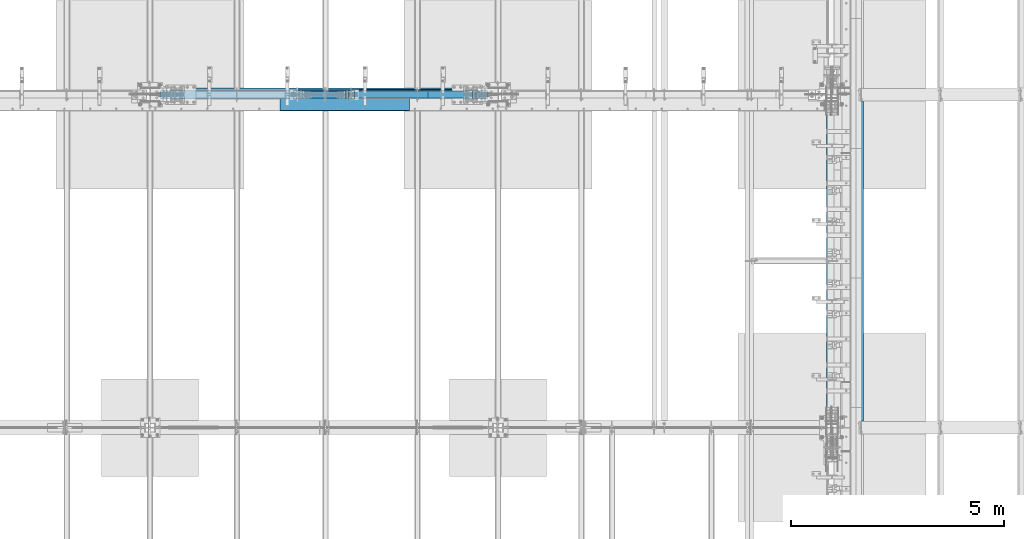
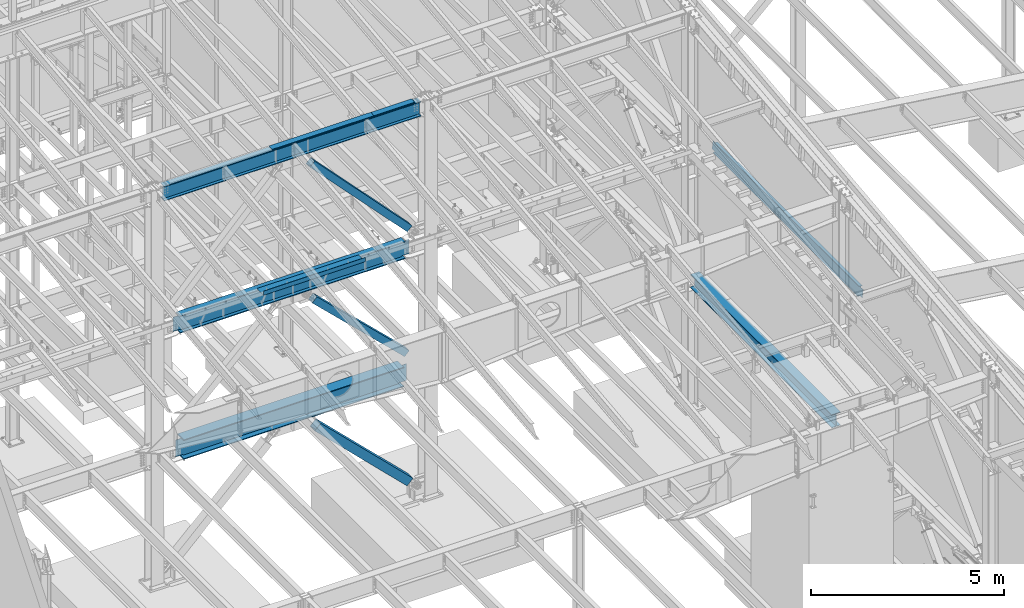
# One storey, part 737 of 1179: 8 beams, 3 members, 8 elements without a shape of their own.
"""IFC2X3 building model written with IfcOpenShell, lengths in millimetres."""

from ifc_helpers import new_model, si_unit, frame, origin_with_axes, place, context, subcontext, project, spatial, faceted_brep, material, type_object, element, aggregate, save


model = new_model("IFC2X3")

# Units and contexts
model_context = context("Model", 3, precision=1e-05, world=origin_with_axes())
body_context = subcontext(model_context, "Body", "Model", "MODEL_VIEW")
ifc_project = project(units=[si_unit("LENGTHUNIT", "METRE", prefix="MILLI"), si_unit("AREAUNIT", "SQUARE_METRE"), si_unit("VOLUMEUNIT", "CUBIC_METRE"), si_unit("MASSUNIT", "GRAM", prefix="KILO"), si_unit("TIMEUNIT", "SECOND"), si_unit("PLANEANGLEUNIT", "RADIAN"), si_unit("SOLIDANGLEUNIT", "STERADIAN"), si_unit("THERMODYNAMICTEMPERATUREUNIT", "DEGREE_CELSIUS"), si_unit("LUMINOUSINTENSITYUNIT", "LUMEN")], contexts=[model_context])

# Site, building, storey
site_placement = place(None, origin_with_axes())
site = spatial("IfcSite", under=ifc_project, at=site_placement, CompositionType="ELEMENT")
building_placement = place(site_placement, origin_with_axes())
building = spatial("IfcBuilding", under=site, at=building_placement, Name="Undefined", CompositionType="ELEMENT")
storey_placement = place(building_placement, origin_with_axes())
storey = spatial("IfcBuildingStorey", under=building, at=storey_placement, Name="Undefined", CompositionType="ELEMENT", Elevation=0.0)

# Assembly, beams
assembly_1_placement = place(storey_placement, origin_with_axes())
assembly_1 = element("IfcElementAssembly", 1, at=assembly_1_placement, inside=storey, Name="BEAM", AssemblyPlace="NOTDEFINED", PredefinedType="RIGID_FRAME")
ifc_material_1 = material(Name="STEEL/A36")
beam_type_1 = type_object("IfcBeamType", PredefinedType="NOTDEFINED")
beam_1_placement = place(assembly_1_placement, frame((15417.8000078236, 27124.0249999997, 12269.3906250174), z_axis=(-1.0, 0.0, 0.0), x_axis=(0.0, 0.0, 1.0)))
beam_1 = element("IfcBeam", 2, at=beam_1_placement, type_object=beam_type_1, material=ifc_material_1, Name="BENT_PLATE", context=body_context, shape_type="Brep", body=[
    faceted_brep([(-2.91038304567337e-11, -4.76250000000073, -609.6), (-2.91038304567337e-11, -4.76250000000073, 609.6), (2.91038304567337e-11, 4.76250000000073, 609.6), (2.91038304567337e-11, 4.76250000000073, -609.6), (43.0065173010735, 4.76249999974607, 609.6), (43.0065173010735, 4.76249999974607, -609.6), (32.3445868583403, -4.7625000001899, -609.6), (32.3445868583403, -4.7625000001899, 609.6), (25.4267481938641, -150.812499999749, 609.6), (25.4267481938641, -150.812499999749, -609.6), (16.9174425397669, -141.287499999748, -609.6), (16.9174425397669, -141.287499999748, 609.6), (3.04971763398498e-08, -150.812499999749, 609.6), (3.04971763398498e-08, -150.812499999749, -609.6), (3.04971763398498e-08, -141.287499999748, 609.6), (3.04971763398498e-08, -141.287499999748, -609.6)], [[[0, 1, 2, 3]], [[3, 2, 4, 5]], [[1, 0, 6, 7]], [[5, 4, 8, 9]], [[7, 6, 10, 11]], [[9, 8, 12, 13]], [[8, 4, 2, 1, 7, 11, 14, 12]], [[11, 10, 15, 14]], [[10, 6, 0, 3, 5, 9, 13, 15]], [[14, 15, 13, 12]]]),
])
beam_2_placement = place(assembly_1_placement, frame((13284.2000078249, 27124.025, 12269.3906249899), z_axis=(-1.0, 0.0, 0.0), x_axis=(0.0, 0.0, 1.0)))
beam_2 = element("IfcBeam", 3, at=beam_2_placement, type_object=beam_type_1, material=ifc_material_1, Name="BENT_PLATE", context=body_context, shape_type="Brep", body=[
    faceted_brep([(-2.91038304567337e-11, -4.76250000000073, -1524.0), (-2.91038304567337e-11, -4.76250000000073, 1524.0), (2.91038304567337e-11, 4.76250000000073, 1524.0), (2.91038304567337e-11, 4.76250000000073, -1524.0), (43.0065173285329, 4.76249999974607, 1524.0), (43.0065173285329, 4.76249999974607, -1524.0), (32.344586885798, -4.7625000001899, -1524.0), (32.344586885798, -4.7625000001899, 1524.0), (25.4267482213236, -150.812499999749, 1524.0), (25.4267482213236, -150.812499999749, -1524.0), (16.9174425672263, -141.287499999748, -1524.0), (16.9174425672263, -141.287499999748, 1524.0), (8.54161044117063e-08, -150.812499999749, 1524.0), (8.54161044117063e-08, -150.812499999749, -1524.0), (8.54161044117063e-08, -141.287499999748, 1524.0), (8.54161044117063e-08, -141.287499999748, -1524.0)], [[[0, 1, 2, 3]], [[3, 2, 4, 5]], [[1, 0, 6, 7]], [[5, 4, 8, 9]], [[7, 6, 10, 11]], [[9, 8, 12, 13]], [[8, 4, 2, 1, 7, 11, 14, 12]], [[11, 10, 15, 14]], [[10, 6, 0, 3, 5, 9, 13, 15]], [[14, 15, 13, 12]]]),
])

# Assembly, member
assembly_2_placement = place(storey_placement, origin_with_axes())
assembly_2 = element("IfcElementAssembly", 4, at=assembly_2_placement, inside=storey, Name="None", AssemblyPlace="NOTDEFINED", PredefinedType="RIGID_FRAME")
ifc_material_2 = material(Name="STEEL/A992")
member_type_1 = type_object("IfcMemberType", Name="HSS8X8X3/16", PredefinedType="NOTDEFINED")
member_1_placement = place(assembly_2_placement, frame((15866.9113752834, 27051.0, 8361.41390796692), z_axis=(0.0, 1.0, 0.0), x_axis=(-0.689394506161204, 0.0, 0.724386095169385)))
member_1 = element("IfcMember", 5, at=member_1_placement, type_object=member_type_1, material=ifc_material_2, Name="None", ObjectType="HSS8X8X3/16", context=body_context, shape_type="Brep", body=[
    faceted_brep([(-3.63797880709171e-12, 96.8374999999978, -96.8375000000015), (-3.63797880709171e-12, -96.8374999999978, -96.8375000000015), (4230.75809404147, -96.8375000024389, -96.8375000000015), (4230.75809404158, 96.8374999976659, -96.8375000000015), (-3.63797880709171e-12, -96.8374999999978, 96.8375000000015), (4230.75809404147, -96.8375000024389, 96.8375000000015), (-3.63797880709171e-12, 96.8374999999978, 96.8375000000015), (4230.75809404158, 96.8374999976659, 96.8375000000015), (-3.63797880709171e-12, 101.599999999999, -101.599999999999), (-3.63797880709171e-12, 101.599999999999, 101.599999999999), (4230.75809404159, 101.59999999767, 101.599999999999), (4230.75809404159, 101.59999999767, -101.599999999999), (0.0, -101.599999999999, 101.599999999999), (4230.75809404147, -101.600000002443, 101.599999999999), (0.0, -101.599999999999, -101.599999999999), (4230.75809404147, -101.600000002443, -101.599999999999)], [[[0, 1, 2, 3]], [[1, 4, 5, 2]], [[4, 6, 7, 5]], [[6, 0, 3, 7]], [[8, 9, 10, 11]], [[9, 12, 13, 10]], [[12, 14, 15, 13]], [[14, 8, 11, 15]], [[13, 15, 11, 10], [5, 7, 3, 2]], [[14, 12, 9, 8], [6, 4, 1, 0]]]),
])
aggregate(assembly_2, [member_1])

assembly_3_placement = place(storey_placement, origin_with_axes())
assembly_3 = element("IfcElementAssembly", 6, at=assembly_3_placement, inside=storey, Name="None", AssemblyPlace="NOTDEFINED", PredefinedType="RIGID_FRAME")
member_2_placement = place(assembly_3_placement, frame((15784.281515407, 27051.0, 4443.21300540147), z_axis=(0.0, 1.0, 0.0), x_axis=(-0.719495300867138, 0.0, 0.694497308871752)))
member_2 = element("IfcMember", 7, at=member_2_placement, type_object=member_type_1, material=ifc_material_2, Name="None", ObjectType="HSS8X8X3/16", context=body_context, shape_type="Brep", body=[
    faceted_brep([(-3.63797880709171e-12, 96.8374999999978, -96.8375000000015), (-3.63797880709171e-12, -96.8374999999978, -96.8375000000015), (3842.17732918352, -96.837500000076, -96.8375000000015), (3842.17732918352, 96.8375000000178, -96.8375000000015), (-3.63797880709171e-12, -96.8374999999978, 96.8375000000015), (3842.17732918352, -96.837500000076, 96.8375000000015), (-3.63797880709171e-12, 96.8374999999978, 96.8375000000015), (3842.17732918352, 96.8375000000178, 96.8375000000015), (-3.63797880709171e-12, 101.599999999999, -101.599999999999), (-3.63797880709171e-12, 101.599999999999, 101.599999999999), (3842.17732918352, 101.600000000024, 101.599999999999), (3842.17732918352, 101.600000000024, -101.599999999999), (0.0, -101.599999999999, 101.599999999999), (3842.17732918352, -101.600000000077, 101.599999999999), (0.0, -101.599999999999, -101.599999999999), (3842.17732918352, -101.600000000077, -101.599999999999)], [[[0, 1, 2, 3]], [[1, 4, 5, 2]], [[4, 6, 7, 5]], [[6, 0, 3, 7]], [[8, 9, 10, 11]], [[9, 12, 13, 10]], [[12, 14, 15, 13]], [[14, 8, 11, 15]], [[13, 15, 11, 10], [5, 7, 3, 2]], [[14, 12, 9, 8], [6, 4, 1, 0]]]),
])
aggregate(assembly_3, [member_2])

# Assembly, beam
assembly_4_placement = place(storey_placement, origin_with_axes())
assembly_4 = element("IfcElementAssembly", 8, at=assembly_4_placement, inside=storey, Name="BEAM", AssemblyPlace="NOTDEFINED", PredefinedType="RIGID_FRAME")
beam_type_2 = type_object("IfcBeamType", PredefinedType="NOTDEFINED")
beam_3_placement = place(assembly_4_placement, frame((12855.575, 26673.175, 8147.05000610352), z_axis=(1.0, 0.0, 0.0), x_axis=(0.0, 0.0, -1.0)))
beam_3 = element("IfcBeam", 9, at=beam_3_placement, type_object=beam_type_2, material=ifc_material_1, Name="BENT_PLATE", context=body_context, shape_type="Brep", body=[
    faceted_brep([(0.0, -3.17499999999927, -1524.0), (6.00266503170133e-10, -3.17499999922438, 1524.00000000052), (6.00266503170133e-10, 3.17500000077416, 1524.00000000052), (0.0, 3.17499999999927, -1524.0), (127.000006103516, 3.17499999999927, 1524.0), (127.000006103516, 3.17499999999927, -1524.0), (133.350006103517, -3.17499999999927, -1524.0), (133.350006103517, -3.17499999999927, 1524.0), (127.000006103516, 346.074999237058, 1524.0), (127.000006103516, 346.074999237058, -1524.0), (133.350006103517, 346.074999237058, 1524.0), (133.350006103517, 346.074999237058, -1524.0)], [[[0, 1, 2, 3]], [[3, 2, 4, 5]], [[1, 0, 6, 7]], [[5, 4, 8, 9]], [[4, 2, 1, 7, 10, 8]], [[7, 6, 11, 10]], [[6, 0, 3, 5, 9, 11]], [[10, 11, 9, 8]]]),
])

# Assembly, member
assembly_5_placement = place(storey_placement, origin_with_axes())
assembly_5 = element("IfcElementAssembly", 10, at=assembly_5_placement, inside=storey, Name="None", AssemblyPlace="NOTDEFINED", PredefinedType="RIGID_FRAME")
member_type_2 = type_object("IfcMemberType", Name="HSS10X10X1/4", PredefinedType="NOTDEFINED")
member_3_placement = place(assembly_5_placement, frame((15863.0925305839, 27051.0, 368.17424440883), z_axis=(0.0, 1.0, 0.0), x_axis=(-0.714279370137245, 0.0, 0.699860687134476)))
member_3 = element("IfcMember", 11, at=member_3_placement, type_object=member_type_2, material=ifc_material_2, Name="None", ObjectType="HSS10X10X1/4", context=body_context, shape_type="Brep", body=[
    faceted_brep([(-6.09361450187862e-11, 120.650000000031, -120.650000000001), (6.00266503170133e-11, -120.650000000031, -120.650000000001), (3864.45514479118, -120.649999998917, -120.650000000001), (3864.45514479113, 120.65000000114, -120.650000000001), (6.00266503170133e-11, -120.650000000031, 120.650000000001), (3864.45514479118, -120.649999998917, 120.650000000001), (-6.09361450187862e-11, 120.650000000031, 120.650000000001), (3864.45514479113, 120.65000000114, 120.650000000001), (-6.3664629124105e-11, 127.000000000032, -127.0), (-6.3664629124105e-11, 127.000000000032, 127.0), (3864.45514479113, 127.000000001141, 127.0), (3864.45514479113, 127.000000001141, -127.0), (6.2755134422332e-11, -127.000000000033, 127.0), (3864.45514479118, -126.99999999892, 127.0), (6.2755134422332e-11, -127.000000000033, -127.0), (3864.45514479118, -126.99999999892, -127.0)], [[[0, 1, 2, 3]], [[1, 4, 5, 2]], [[4, 6, 7, 5]], [[6, 0, 3, 7]], [[8, 9, 10, 11]], [[9, 12, 13, 10]], [[12, 14, 15, 13]], [[14, 8, 11, 15]], [[13, 15, 11, 10], [5, 7, 3, 2]], [[14, 12, 9, 8], [6, 4, 1, 0]]]),
])
aggregate(assembly_5, [member_3])

# Beam
beam_type_3 = type_object("IfcBeamType", Name="W18X65", PredefinedType="NOTDEFINED")
beam_4_placement = place(assembly_1_placement, frame((8280.4, 27050.9999999701, 12036.0281250357), z_axis=(0.0, 0.0, 1.0), x_axis=(1.0, 0.0, 0.0)))
beam_4 = element("IfcBeam", 12, at=beam_4_placement, type_object=beam_type_3, material=ifc_material_2, Name="BEAM", ObjectType="W18X65", context=body_context, shape_type="Brep", body=[
    faceted_brep([(247.650000000016, -96.8375000000015, -233.362499999999), (247.650000000016, 96.8375000000015, -233.362499999999), (7931.14999999999, 96.8375000000015, -233.362499999999), (7931.14999999999, -96.8375000000015, -233.362499999999), (247.650000000016, -96.8375000000015, -214.3125), (247.650000000016, -5.55625000000146, -214.3125), (247.650000000016, -5.55625000000146, 214.3125), (247.650000000016, -96.8375000000015, 214.3125), (247.650000000016, -96.8375000000015, 233.362499999999), (247.650000000016, 96.8375000000015, 233.362499999999), (247.650000000016, 96.8375000000015, 214.3125), (247.650000000016, 5.55625000000146, 214.3125), (247.650000000016, 5.55625000000146, 196.00250000013), (247.650000000016, 5.55625000000146, -110.277499999971), (247.650000000016, 5.55625000000146, -214.3125), (247.650000000016, 96.8375000000015, -214.3125), (7931.14999999999, -96.8375000000015, -214.3125), (7931.14999999999, -5.55625000000146, -214.3125), (7931.14999999999, -5.55625000000146, 214.3125), (7931.14999999999, -96.8375000000015, 214.3125), (7931.14999999999, -96.8375000000015, 233.362499999999), (7931.14999999999, 96.8375000000015, 233.362499999999), (7931.14999999999, 96.8375000000015, 214.3125), (7931.14999999999, 5.55625000000146, 214.3125), (7931.14999999999, 5.55625000000146, 196.00250000013), (7931.14999999999, 5.55625000000146, -110.277499999971), (7931.14999999999, 5.55625000000146, -214.3125), (7931.14999999999, 96.8375000000015, -214.3125)], [[[0, 1, 2, 3]], [[0, 4, 5, 6, 7, 8, 9, 10, 11, 12, 13, 14, 15, 1]], [[5, 4, 16, 17]], [[6, 5, 17, 18]], [[7, 6, 18, 19]], [[8, 7, 19, 20]], [[9, 8, 20, 21]], [[10, 9, 21, 22]], [[11, 10, 22, 23]], [[14, 13, 12, 11, 23, 24, 25, 26]], [[15, 14, 26, 27]], [[1, 15, 27, 2]], [[26, 25, 24, 23, 22, 21, 20, 19, 18, 17, 16, 3, 2, 27]], [[4, 0, 3, 16]]]),
])

aggregate(assembly_1, [beam_1, beam_2, beam_4])

# Assembly, beam
assembly_6_placement = place(storey_placement, origin_with_axes())
assembly_6 = element("IfcElementAssembly", 13, at=assembly_6_placement, inside=storey, Name="BEAM", AssemblyPlace="NOTDEFINED", PredefinedType="RIGID_FRAME")
beam_type_4 = type_object("IfcBeamType", Name="W12X22", PredefinedType="NOTDEFINED")
beam_5_placement = place(assembly_6_placement, frame((24972.7820076832, 19227.8, 7789.85835822087), z_axis=(0.133813223953133, 0.0, 0.991006569652931), x_axis=(0.0, 1.0, 0.0)))
beam_5 = element("IfcBeam", 14, at=beam_5_placement, type_object=beam_type_4, material=ifc_material_2, Name="BEAM", ObjectType="W12X22", context=body_context, shape_type="Brep", body=[
    faceted_brep([(7661.27499999999, -3.17499999982829, -144.462500000049), (7661.27499999999, -50.7999999998501, -144.462500000061), (7661.27499999999, -50.7999999998283, -155.575000000066), (7661.27499999999, 50.8000000001921, -155.575000000039), (7661.27499999999, 50.8000000001775, -144.462500000034), (7661.27499999999, 3.17500000017026, -144.462500000049), (7661.27499999999, 3.17500000016298, -136.524999801411), (7661.27499999999, -3.17499999984284, -136.524999801408), (7662.24172992258, 3.17500000015571, -131.664920283361), (7662.24172992258, -3.17499999984284, -131.664920283358), (7664.99474382306, 3.17500000014843, -127.544743815204), (7664.99474382306, -3.17499999985012, -127.5447438152), (7669.11492029121, 3.17500000015571, -124.791729914723), (7669.11492029121, -3.17499999985012, -124.791729914719), (7673.97499980926, 3.17500000014115, -123.824999992134), (7673.97499980926, -3.17499999985739, -123.82499999213), (7802.5625, -3.17499999985739, -123.824999992026), (7802.5625, 3.17500000014115, -123.824999992017), (161.925000000007, 3.17499999983556, 144.462500000051), (161.925000000007, 50.7999999998428, 144.462500000063), (7661.275, 50.7999999998356, 144.462500000063), (7661.275, 3.17499999982829, 144.462500000051), (161.925000000007, -3.17499999984284, -136.524999799629), (161.925000000007, 3.17500000016298, -136.524999799632), (161.925000000007, 3.17500000017026, -144.462500000049), (161.925000000007, 50.8000000001775, -144.462500000034), (161.925000000007, 50.8000000001994, -155.575000000039), (161.925000000007, -50.7999999998283, -155.575000000066), (161.925000000007, -50.7999999998428, -144.462500000063), (161.925000000007, -3.17499999982101, -144.462500000049), (160.958270077419, -3.17499999984284, -131.664920281577), (160.958270077419, 3.17500000015571, -131.664920281581), (158.205256176941, -3.17499999984284, -127.54474381342), (158.205256176941, 3.17500000014843, -127.544743813425), (154.085079708788, -3.17499999985012, -124.791729912939), (154.085079708788, 3.17500000015571, -124.791729912944), (149.225000190741, -3.17499999985012, -123.824999990349), (149.225000190741, 3.17500000014115, -123.824999990355), (20.6375000000044, -3.17499999985739, -123.824999990466), (20.6375000000044, 3.17500000014843, -123.824999990458), (20.6375000000044, -3.17500000014115, 117.475000009781), (20.6375000000044, 3.17499999986467, 117.475000009788), (149.225000190741, -3.17500000014115, 117.475000009897), (149.225000190741, 3.17499999986467, 117.475000009894), (154.085079708788, -3.17500000014115, 118.441729932485), (154.085079708788, 3.17499999986467, 118.441729932481), (158.205256176941, -3.17500000014843, 121.194743832966), (158.205256176941, 3.17499999985739, 121.194743832963), (160.958270077419, -3.17500000014843, 125.314920301123), (160.958270077419, 3.17499999985739, 125.31492030112), (161.925000000007, -3.17500000014843, 130.174999819174), (161.925000000007, 3.17499999985012, 130.17499981917), (161.925000000007, -50.8000000001994, 155.575000000041), (161.925000000007, 50.7999999998356, 155.575000000066), (161.925000000007, -3.17500000017026, 144.462500000049), (161.925000000007, -50.8000000001775, 144.462500000034), (7661.275, -3.17500000017753, 144.462500000049), (7661.275, -50.8000000001775, 144.462500000034), (7661.275, -50.8000000001994, 155.575000000041), (7661.275, 50.7999999998283, 155.575000000068), (7661.275, -3.17500000016298, 130.174999817395), (7661.275, 3.17499999985012, 130.174999817391), (7662.24172992259, -3.17500000015571, 125.314920299345), (7662.24172992259, 3.17499999985012, 125.314920299341), (7664.99474382306, -3.17500000014843, 121.194743831187), (7664.99474382306, 3.17499999985739, 121.194743831182), (7669.11492029122, -3.17500000014115, 118.441729930706), (7669.11492029122, 3.17499999986467, 118.441729930701), (7673.97499980926, -3.17500000014115, 117.475000008115), (7673.97499980926, 3.17499999986467, 117.475000008111), (7802.5625, -3.17500000014115, 117.47500000822), (7802.5625, 3.17499999985739, 117.475000008229)], [[[0, 1, 2, 3, 4, 5, 6, 7]], [[7, 6, 8, 9]], [[9, 8, 10, 11]], [[11, 10, 12, 13]], [[13, 12, 14, 15]], [[16, 15, 14, 17]], [[18, 19, 20, 21]], [[22, 23, 24, 25, 26, 27, 28, 29]], [[30, 31, 23, 22]], [[32, 33, 31, 30]], [[34, 35, 33, 32]], [[36, 37, 35, 34]], [[38, 39, 37, 36]], [[40, 41, 39, 38]], [[42, 43, 41, 40]], [[44, 45, 43, 42]], [[46, 47, 45, 44]], [[48, 49, 47, 46]], [[50, 51, 49, 48]], [[52, 53, 19, 18, 51, 50, 54, 55]], [[55, 54, 56, 57]], [[52, 55, 57, 58]], [[53, 52, 58, 59]], [[19, 53, 59, 20]], [[58, 57, 56, 60, 61, 21, 20, 59]], [[62, 63, 61, 60]], [[64, 65, 63, 62]], [[66, 67, 65, 64]], [[68, 69, 67, 66]], [[70, 71, 69, 68]], [[71, 70, 16, 17]], [[12, 10, 8, 6, 5, 24, 23, 31, 33, 35, 37, 39, 41, 43, 45, 47, 49, 51, 18, 21, 61, 63, 65, 67, 69, 71, 17, 14]], [[25, 24, 5, 4]], [[26, 25, 4, 3]], [[27, 26, 3, 2]], [[28, 27, 2, 1]], [[29, 28, 1, 0]], [[70, 68, 66, 64, 62, 60, 56, 54, 50, 48, 46, 44, 42, 40, 38, 36, 34, 32, 30, 22, 29, 0, 7, 9, 11, 13, 15, 16]]]),
])
aggregate(assembly_6, [beam_5])

# Beam
beam_type_5 = type_object("IfcBeamType", Name="W21X93", PredefinedType="NOTDEFINED")
beam_6_placement = place(assembly_4_placement, frame((8280.4000000485, 27051.0, 7739.0625), z_axis=(0.0, 0.0, 1.0), x_axis=(1.0, 0.0, 0.0)))
beam_6 = element("IfcBeam", 15, at=beam_6_placement, type_object=beam_type_5, material=ifc_material_2, Name="BEAM", ObjectType="W21X93", context=body_context, shape_type="Brep", body=[
    faceted_brep([(7467.59106647632, -106.362499999999, 250.825), (7467.59106647632, -7.14374999999927, 250.825), (7467.82028126332, -7.14374999999927, 250.428), (7467.82028126332, 7.14374999999927, 250.428), (7467.59106647632, 7.14374999999927, 250.825), (7467.59106647632, 106.362499999999, 250.825), (7453.84250951058, 106.362499999999, 274.6375), (7453.84250951058, -106.362499999999, 274.6375), (724.957501572533, -106.362499999999, -250.825), (711.20933470574, -106.362499999999, -274.6375), (7467.59066336998, -106.362499999999, -274.6375), (7453.84249650319, -106.362499999999, -250.825), (711.20933470574, 106.362499999999, -274.6375), (7467.59066336998, 106.362499999999, -274.6375), (724.957501572533, 106.362499999999, -250.825), (7453.84249650319, 106.362499999999, -250.825), (724.957501572533, 7.14374999999927, -250.825), (7453.84249650319, 7.14374999999927, -250.825), (7410.15171573958, -7.14374999999927, 243.568356973128), (7410.15171573958, 7.14374999999927, 243.568356973128), (7424.72807993658, 7.14374999999927, 250.428), (7424.72807993658, -7.14374999999927, 250.428), (7406.29596713053, -7.14374999999927, 240.254052423033), (7406.29596713053, 7.14374999999927, 240.254052423033), (7404.69454065578, -7.14374999999927, 235.428407882362), (7404.69454065578, 7.14374999999927, 235.428407882362), (7405.80374773652, -7.14374999999927, 230.466445403767), (7405.80374773652, 7.14374999999927, 230.466445403767), (7409.3075302412, -7.14374999999927, 226.782029554974), (7409.3075302412, 7.14374999999927, 226.782029554974), (7414.20751827933, -7.14374999999927, 225.425), (7414.20751827933, 7.14374999999927, 225.425), (7616.81607993658, -7.14374999999927, 225.425), (7616.81607993658, 7.14374999999927, 225.425), (7616.81607993658, -7.14374999999927, -225.425), (7616.81607993658, 7.14374999999927, -225.425), (7411.11351827933, -7.14374999999927, -225.425), (7411.11351827933, 7.14374999999927, -225.425), (7406.2135302412, -7.14374999999927, -226.782029554975), (7406.2135302412, 7.14374999999927, -226.782029554975), (7402.70974773652, -7.14374999999927, -230.466445403767), (7402.70974773652, 7.14374999999927, -230.466445403767), (7401.60054065578, -7.14374999999927, -235.428407882363), (7401.60054065578, 7.14374999999927, -235.428407882363), (7403.20196713053, -7.14374999999927, -240.254052423033), (7403.20196713053, 7.14374999999927, -240.254052423033), (7407.05771573958, -7.14374999999927, -243.568356973128), (7407.05771573958, 7.14374999999927, -243.568356973128), (7421.63407993658, -7.14374999999927, -250.428), (7421.63407993658, 7.14374999999927, -250.428), (7453.61328821989, -7.14374999999927, -250.428), (7453.61328821989, 7.14374999999927, -250.428), (7453.84249650319, -7.14374999999927, -250.825), (724.957501572533, -7.14374999999927, -250.825), (725.186709855834, -7.14374999999927, -250.428), (725.186709855834, 7.14374999999927, -250.428), (763.515918139135, -7.14374999999927, -250.428), (763.515918139135, 7.14374999999927, -250.428), (781.790495052202, -7.14374999999927, -243.923533666101), (781.790495052202, 7.14374999999927, -243.923533666101), (786.068833834523, -7.14374999999927, -240.856821654457), (786.068833834523, 7.14374999999927, -240.856821654457), (788.065028999563, -7.14374999999927, -235.986081447699), (788.065028999563, 7.14374999999927, -235.986081447699), (787.169413904452, -7.14374999999927, -230.798906985616), (787.169413904452, 7.14374999999927, -230.798906985616), (783.65552224865, -7.14374999999927, -226.87953576947), (783.65552224865, 7.14374999999927, -226.87953576947), (778.596546957744, -7.14374999999927, -225.425), (778.596546957744, 7.14374999999927, -225.425), (561.983918139136, -7.14374999999927, -225.425), (561.983918139136, 7.14374999999927, -225.425), (561.983918139136, -7.14374999999927, 225.425), (561.983918139136, 7.14374999999927, 225.425), (778.677546957742, -7.14374999999927, 225.425000000001), (778.677546957742, 7.14374999999927, 225.425000000001), (783.736522248651, -7.14374999999927, 226.879535769469), (783.736522248651, 7.14374999999927, 226.879535769469), (787.250413904452, -7.14374999999927, 230.798906985616), (787.250413904452, 7.14374999999927, 230.798906985616), (788.146028999565, -7.14374999999927, 235.986081447698), (788.146028999565, 7.14374999999927, 235.986081447698), (786.149833834525, -7.14374999999927, 240.856821654457), (786.149833834525, 7.14374999999927, 240.856821654457), (781.871495052201, -7.14374999999927, 243.923533666102), (781.871495052201, 7.14374999999927, 243.923533666102), (763.596918139136, -7.14374999999927, 250.428), (763.596918139136, 7.14374999999927, 250.428), (710.979716812397, -7.14374999999927, 250.428), (710.979716812397, 7.14374999999927, 250.428), (724.957488565138, -106.362499999999, 274.6375), (724.957488565138, 106.362499999999, 274.6375), (711.208931599396, 106.362499999999, 250.825), (711.208931599396, 7.14374999999927, 250.825), (711.208931599396, -7.14374999999927, 250.825), (711.208931599396, -106.362499999999, 250.825)], [[[0, 1, 2, 3, 4, 5, 6, 7]], [[8, 9, 10, 11]], [[9, 12, 13, 10]], [[12, 14, 15, 13]], [[14, 16, 17, 15]], [[18, 19, 20, 21]], [[22, 23, 19, 18]], [[24, 25, 23, 22]], [[26, 27, 25, 24]], [[28, 29, 27, 26]], [[30, 31, 29, 28]], [[31, 30, 32, 33]], [[32, 34, 35, 33]], [[36, 37, 35, 34]], [[38, 39, 37, 36]], [[40, 41, 39, 38]], [[42, 43, 41, 40]], [[44, 45, 43, 42]], [[46, 47, 45, 44]], [[48, 49, 47, 46]], [[49, 48, 50, 51]], [[10, 13, 15, 17, 51, 50, 52, 11]], [[53, 8, 11, 52]], [[54, 55, 16, 14, 12, 9, 8, 53]], [[56, 57, 55, 54]], [[58, 59, 57, 56]], [[60, 61, 59, 58]], [[62, 63, 61, 60]], [[64, 65, 63, 62]], [[66, 67, 65, 64]], [[68, 69, 67, 66]], [[69, 68, 70, 71]], [[72, 73, 71, 70]], [[74, 75, 73, 72]], [[76, 77, 75, 74]], [[78, 79, 77, 76]], [[80, 81, 79, 78]], [[82, 83, 81, 80]], [[84, 85, 83, 82]], [[86, 87, 85, 84]], [[87, 86, 88, 89]], [[90, 91, 92, 93, 89, 88, 94, 95]], [[90, 95, 0, 7]], [[91, 90, 7, 6]], [[92, 91, 6, 5]], [[93, 92, 5, 4]], [[20, 19, 23, 25, 27, 29, 31, 33, 35, 37, 39, 41, 43, 45, 47, 49, 51, 17, 16, 55, 57, 59, 61, 63, 65, 67, 69, 71, 73, 75, 77, 79, 81, 83, 85, 87, 89, 93, 4, 3]], [[21, 20, 3, 2]], [[94, 88, 86, 84, 82, 80, 78, 76, 74, 72, 70, 68, 66, 64, 62, 60, 58, 56, 54, 53, 52, 50, 48, 46, 44, 42, 40, 38, 36, 34, 32, 30, 28, 26, 24, 22, 18, 21, 2, 1]], [[95, 94, 1, 0]]]),
])

aggregate(assembly_4, [beam_3, beam_6])

# Assembly, beam
assembly_7_placement = place(storey_placement, origin_with_axes())
assembly_7 = element("IfcElementAssembly", 16, at=assembly_7_placement, inside=storey, Name="BEAM", AssemblyPlace="NOTDEFINED", PredefinedType="RIGID_FRAME")
beam_type_6 = type_object("IfcBeamType", Name="W16X77", PredefinedType="NOTDEFINED")
beam_7_placement = place(assembly_7_placement, frame((24307.8, 19227.8, 3892.55), z_axis=(0.0, 0.0, 1.0), x_axis=(0.0, 1.0, 0.0)))
beam_7 = element("IfcBeam", 17, at=beam_7_placement, type_object=beam_type_6, material=ifc_material_2, Name="BEAM", ObjectType="W16X77", context=body_context, shape_type="Brep", body=[
    faceted_brep([(247.650000000001, -130.174999999999, -209.55), (247.650000000001, 130.174999999999, -209.55), (7575.55, 130.174999999999, -209.55), (7575.55, -130.174999999999, -209.55), (247.650000000001, -130.174999999999, -190.5), (247.649999999994, -5.55624999999998, -190.5), (247.649999999994, -5.55624999999998, 190.5), (247.650000000001, -130.174999999999, 190.5), (247.650000000001, -130.174999999999, 209.55), (247.650000000001, 130.174999999999, 209.55), (247.650000000001, 130.174999999999, 190.5), (247.649999999994, 5.55624999999998, 190.5), (247.650000000001, 5.55625000000146, 159.490000000109), (247.650000000001, 5.55625000000146, -146.789999999992), (247.649999999994, 5.55624999999998, -190.5), (247.650000000001, 130.174999999999, -190.5), (7575.55, -130.174999999999, -190.5), (7575.55, -5.55625000000146, -190.5), (7575.55, -5.55625000000146, 190.5), (7575.55, -130.174999999999, 190.5), (7575.55, -130.174999999999, 209.55), (7575.55, 130.174999999999, 209.55), (7575.55, 130.174999999999, 190.5), (7575.55, 5.55625000000146, 190.5), (7575.55, 5.55625000000146, 159.490000000113), (7575.55, 5.55625000000146, -146.789999999991), (7575.55, 5.55625000000146, -190.5), (7575.55, 130.174999999999, -190.5)], [[[0, 1, 2, 3]], [[0, 4, 5, 6, 7, 8, 9, 10, 11, 12, 13, 14, 15, 1]], [[5, 4, 16, 17]], [[6, 5, 17, 18]], [[7, 6, 18, 19]], [[8, 7, 19, 20]], [[9, 8, 20, 21]], [[10, 9, 21, 22]], [[11, 10, 22, 23]], [[14, 13, 12, 11, 23, 24, 25, 26]], [[15, 14, 26, 27]], [[1, 15, 27, 2]], [[26, 25, 24, 23, 22, 21, 20, 19, 18, 17, 16, 3, 2, 27]], [[4, 0, 3, 16]]]),
])
aggregate(assembly_7, [beam_7])

assembly_8_placement = place(storey_placement, origin_with_axes())
assembly_8 = element("IfcElementAssembly", 18, at=assembly_8_placement, inside=storey, Name="BEAM", AssemblyPlace="NOTDEFINED", PredefinedType="RIGID_FRAME")
beam_type_7 = type_object("IfcBeamType", Name="W24X131", PredefinedType="NOTDEFINED")
beam_8_placement = place(assembly_8_placement, frame((8280.4, 27051.0, 3790.95), z_axis=(0.0, 0.0, 1.0), x_axis=(1.0, 0.0, 0.0)))
beam_8 = element("IfcBeam", 19, at=beam_8_placement, type_object=beam_type_7, material=ifc_material_2, Name="BEAM", ObjectType="W24X131", context=body_context, shape_type="Brep", body=[
    faceted_brep([(800.751695425999, -163.512500000001, 311.15), (800.751695425999, 163.512500000001, 311.15), (787.003138460255, 163.512500000001, 287.3375), (787.003138460255, 7.9375, 287.3375), (786.773923673256, 7.9375, 286.9405), (786.773923673256, -7.9375, 286.9405), (787.003138460255, -7.9375, 287.3375), (787.003138460255, -163.512500000001, 287.3375), (839.391124999996, -7.9375, 286.9405), (839.391124999996, 7.9375, 286.9405), (857.665701913063, 7.9375, 280.436033666101), (857.665701913063, -7.9375, 280.436033666101), (861.944040695387, 7.9375, 277.369321654457), (861.944040695387, -7.9375, 277.369321654457), (863.940235860427, 7.9375, 272.498581447698), (863.940235860427, -7.9375, 272.498581447698), (863.044620765315, 7.9375, 267.311406985616), (863.044620765315, -7.9375, 267.311406985616), (859.530729109514, 7.9375, 263.392035769469), (859.530729109514, -7.9375, 263.392035769469), (854.471753818605, 7.9375, 261.9375), (854.471753818605, -7.9375, 261.9375), (637.778124999997, 7.9375, 261.9375), (637.778124999997, -7.9375, 261.9375), (637.778124999997, 7.9375, -261.9375), (637.778124999997, -7.9375, -261.9375), (854.390753818605, 7.9375, -261.9375), (854.390753818605, -7.9375, -261.9375), (859.449729109512, 7.9375, -263.39203576947), (859.449729109512, -7.9375, -263.39203576947), (862.963620765313, 7.9375, -267.311406985616), (862.963620765313, -7.9375, -267.311406985616), (863.859235860426, 7.9375, -272.498581447698), (863.859235860426, -7.9375, -272.498581447698), (861.863040695385, 7.9375, -277.369321654458), (861.863040695385, -7.9375, -277.369321654458), (857.584701913063, 7.9375, -280.436033666101), (857.584701913063, -7.9375, -280.436033666101), (839.310124999996, 7.9375, -286.9405), (839.310124999996, -7.9375, -286.9405), (800.980916716695, 7.9375, -286.9405), (800.980916716695, -7.9375, -286.9405), (7378.01440578879, 7.9375, -287.3375), (7378.01440578879, 163.512500000001, -287.3375), (800.751708433392, 163.512500000001, -287.3375), (800.751708433392, 7.9375, -287.3375), (7391.76257265559, 163.512500000001, -311.15), (787.003541566599, 163.512500000001, -311.15), (7391.76257265559, -163.512500000001, -311.15), (787.003541566599, -163.512500000001, -311.15), (7378.01440578879, -163.512500000001, -287.3375), (800.751708433392, -163.512500000001, -287.3375), (800.751708433392, -7.9375, -287.3375), (7378.01440578879, -7.9375, -287.3375), (7377.78519750549, 7.9375, -286.9405), (7377.78519750549, -7.9375, -286.9405), (7339.45598922219, 7.9375, -286.9405), (7339.45598922219, -7.9375, -286.9405), (7321.18141230912, 7.9375, -280.436033666101), (7321.18141230912, -7.9375, -280.436033666101), (7316.9030735268, 7.9375, -277.369321654458), (7316.9030735268, -7.9375, -277.369321654458), (7314.90687836176, 7.9375, -272.498581447698), (7314.90687836176, -7.9375, -272.498581447698), (7315.80249345687, 7.9375, -267.311406985616), (7315.80249345687, -7.9375, -267.311406985616), (7319.31638511267, 7.9375, -263.39203576947), (7319.31638511267, -7.9375, -263.39203576947), (7324.37536040358, 7.9375, -261.9375), (7324.37536040358, -7.9375, -261.9375), (7540.98798922219, 7.9375, -261.9375), (7540.98798922219, -7.9375, -261.9375), (7540.98798922219, -7.9375, 261.9375), (7540.98798922219, 7.9375, 261.9375), (7324.29436040358, 7.9375, 261.9375), (7324.29436040358, -7.9375, 261.9375), (7319.23538511267, 7.9375, 263.392035769469), (7319.23538511267, -7.9375, 263.392035769469), (7315.72149345687, 7.9375, 267.311406985616), (7315.72149345687, -7.9375, 267.311406985616), (7314.82587836176, 7.9375, 272.498581447698), (7314.82587836176, -7.9375, 272.498581447698), (7316.8220735268, 7.9375, 277.369321654457), (7316.8220735268, -7.9375, 277.369321654457), (7321.10041230912, 7.9375, 280.436033666101), (7321.10041230912, -7.9375, 280.436033666101), (7339.37498922219, 7.9375, 286.9405), (7339.37498922219, -7.9375, 286.9405), (7391.99219054893, 7.9375, 286.9405), (7391.99219054893, -7.9375, 286.9405), (7391.76297576193, -163.512500000001, 287.3375), (7391.76297576193, -7.9375, 287.3375), (7391.76297576193, 7.9375, 287.3375), (7391.76297576193, 163.512500000001, 287.3375), (7378.01441879619, 163.512500000001, 311.15), (7378.01441879619, -163.512500000001, 311.15)], [[[0, 1, 2, 3, 4, 5, 6, 7]], [[8, 9, 10, 11]], [[11, 10, 12, 13]], [[13, 12, 14, 15]], [[15, 14, 16, 17]], [[17, 16, 18, 19]], [[19, 18, 20, 21]], [[21, 20, 22, 23]], [[23, 22, 24, 25]], [[26, 27, 25, 24]], [[27, 26, 28, 29]], [[29, 28, 30, 31]], [[31, 30, 32, 33]], [[33, 32, 34, 35]], [[35, 34, 36, 37]], [[37, 36, 38, 39]], [[39, 38, 40, 41]], [[42, 43, 44, 45]], [[43, 46, 47, 44]], [[46, 48, 49, 47]], [[48, 50, 51, 49]], [[41, 40, 45, 44, 47, 49, 51, 52]], [[50, 53, 52, 51]], [[48, 46, 43, 42, 54, 55, 53, 50]], [[56, 57, 55, 54]], [[57, 56, 58, 59]], [[59, 58, 60, 61]], [[61, 60, 62, 63]], [[63, 62, 64, 65]], [[65, 64, 66, 67]], [[67, 66, 68, 69]], [[69, 68, 70, 71]], [[72, 71, 70, 73]], [[74, 75, 72, 73]], [[75, 74, 76, 77]], [[77, 76, 78, 79]], [[79, 78, 80, 81]], [[81, 80, 82, 83]], [[83, 82, 84, 85]], [[85, 84, 86, 87]], [[87, 86, 88, 89]], [[90, 91, 89, 88, 92, 93, 94, 95]], [[90, 95, 0, 7]], [[91, 90, 7, 6]], [[8, 11, 13, 15, 17, 19, 21, 23, 25, 27, 29, 31, 33, 35, 37, 39, 41, 52, 53, 55, 57, 59, 61, 63, 65, 67, 69, 71, 72, 75, 77, 79, 81, 83, 85, 87, 89, 91, 6, 5]], [[9, 8, 5, 4]], [[92, 88, 86, 84, 82, 80, 78, 76, 74, 73, 70, 68, 66, 64, 62, 60, 58, 56, 54, 42, 45, 40, 38, 36, 34, 32, 30, 28, 26, 24, 22, 20, 18, 16, 14, 12, 10, 9, 4, 3]], [[93, 92, 3, 2]], [[94, 93, 2, 1]], [[95, 94, 1, 0]]]),
])
aggregate(assembly_8, [beam_8])

save(model, "model.ifc")
